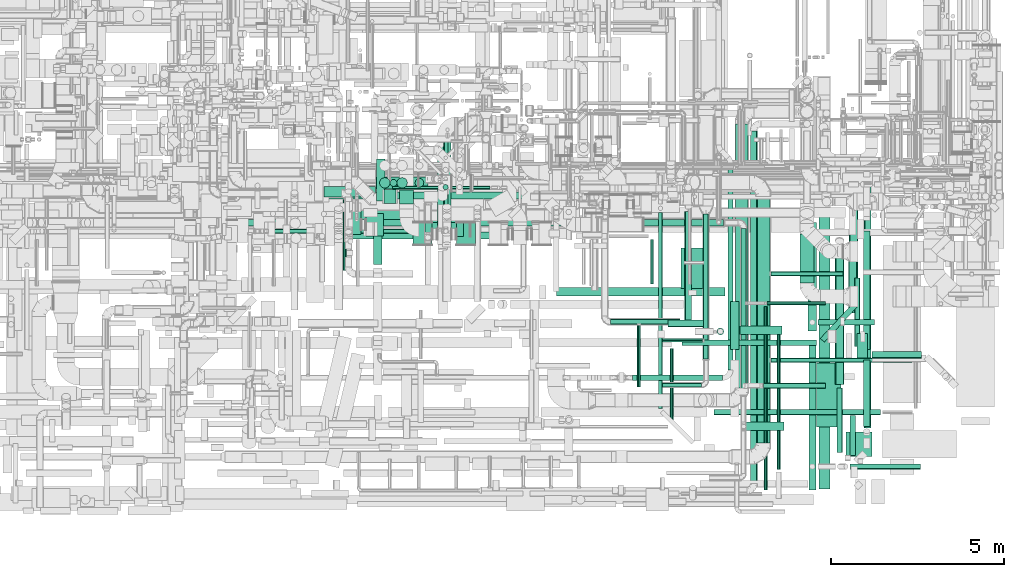
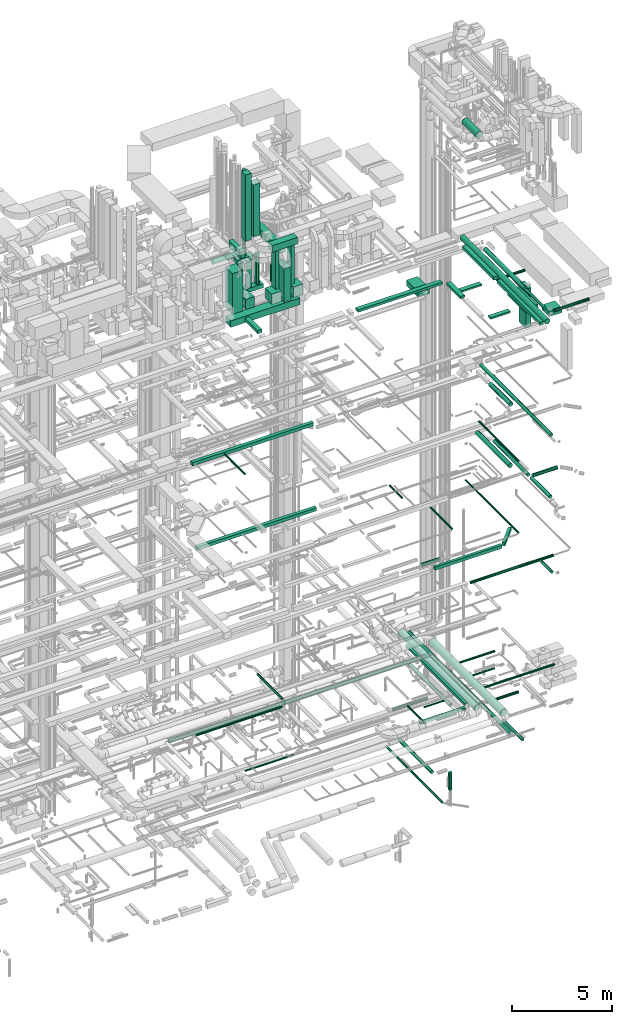
# One storey, part 50 of 337: 79 flow segments.
"""IFC2X3 building model written with IfcOpenShell, lengths in millimetres."""

from ifc_helpers import new_model, entity, si_unit, converted_unit, derived_unit, direction, frame, origin, origin_2d_with_axis, place, context, subcontext, project, spatial, rectangle, circle, extrude, type_object, element, save


model = new_model("IFC2X3")

# Units and contexts
model_context = context("Model", 3, precision=0.01, world=origin(), true_north=direction((6.12303176911189e-17, 1.0)))
body_context = subcontext(model_context, "Body", "Model", "MODEL_VIEW")
ifc_project = project(units=[si_unit("LENGTHUNIT", "METRE", prefix="MILLI"), si_unit("AREAUNIT", "SQUARE_METRE"), si_unit("VOLUMEUNIT", "CUBIC_METRE"), converted_unit("PLANEANGLEUNIT", "DEGREE", entity("IfcRatioMeasure", 0.0174532925199433), si_unit("PLANEANGLEUNIT", "RADIAN"), dimensions=[0, 0, 0, 0, 0, 0, 0]), si_unit("MASSUNIT", "GRAM", prefix="KILO"), derived_unit("MASSDENSITYUNIT", [(si_unit("MASSUNIT", "GRAM", prefix="KILO"), 1), (si_unit("LENGTHUNIT", "METRE"), -3)]), derived_unit("MOMENTOFINERTIAUNIT", [(si_unit("LENGTHUNIT", "METRE"), 4)]), si_unit("TIMEUNIT", "SECOND"), si_unit("FREQUENCYUNIT", "HERTZ"), si_unit("THERMODYNAMICTEMPERATUREUNIT", "DEGREE_CELSIUS"), derived_unit("THERMALTRANSMITTANCEUNIT", [(si_unit("MASSUNIT", "GRAM", prefix="KILO"), 1), (si_unit("THERMODYNAMICTEMPERATUREUNIT", "KELVIN"), -1), (si_unit("TIMEUNIT", "SECOND"), -3)]), derived_unit("VOLUMETRICFLOWRATEUNIT", [(si_unit("LENGTHUNIT", "METRE"), 3), (si_unit("TIMEUNIT", "SECOND"), -1)]), derived_unit("MASSFLOWRATEUNIT", [(si_unit("MASSUNIT", "GRAM", prefix="KILO"), 1), (si_unit("TIMEUNIT", "SECOND"), -1)]), derived_unit("ROTATIONALFREQUENCYUNIT", [(si_unit("TIMEUNIT", "SECOND"), -1)]), si_unit("ELECTRICCURRENTUNIT", "AMPERE"), si_unit("ELECTRICVOLTAGEUNIT", "VOLT"), si_unit("POWERUNIT", "WATT"), si_unit("FORCEUNIT", "NEWTON", prefix="KILO"), si_unit("ILLUMINANCEUNIT", "LUX"), si_unit("LUMINOUSFLUXUNIT", "LUMEN"), si_unit("LUMINOUSINTENSITYUNIT", "CANDELA"), derived_unit("USERDEFINED", [(si_unit("MASSUNIT", "GRAM", prefix="KILO"), -1), (si_unit("LENGTHUNIT", "METRE"), -2), (si_unit("TIMEUNIT", "SECOND"), 3), (si_unit("LUMINOUSFLUXUNIT", "LUMEN"), 1)]), derived_unit("LINEARVELOCITYUNIT", [(si_unit("LENGTHUNIT", "METRE"), 1), (si_unit("TIMEUNIT", "SECOND"), -1)]), si_unit("PRESSUREUNIT", "PASCAL"), derived_unit("USERDEFINED", [(si_unit("LENGTHUNIT", "METRE"), -2), (si_unit("MASSUNIT", "GRAM", prefix="KILO"), 1), (si_unit("TIMEUNIT", "SECOND"), -2)]), derived_unit("LINEARFORCEUNIT", [(si_unit("MASSUNIT", "GRAM", prefix="KILO"), 1), (si_unit("LENGTHUNIT", "METRE"), 1), (si_unit("TIMEUNIT", "SECOND"), -2), (si_unit("LENGTHUNIT", "METRE"), -1)]), derived_unit("PLANARFORCEUNIT", [(si_unit("MASSUNIT", "GRAM", prefix="KILO"), 1), (si_unit("LENGTHUNIT", "METRE"), 1), (si_unit("TIMEUNIT", "SECOND"), -2), (si_unit("LENGTHUNIT", "METRE"), -2)])], contexts=[model_context])

# Site, building, storey
site_placement = place(None, origin())
site = spatial("IfcSite", under=ifc_project, at=site_placement, CompositionType="ELEMENT")
building_placement = place(site_placement, origin())
building = spatial("IfcBuilding", under=site, at=building_placement, CompositionType="ELEMENT")
storey_placement = place(building_placement, origin())
storey = spatial("IfcBuildingStorey", under=building, at=storey_placement, CompositionType="ELEMENT", Elevation=0.0)

# Flow segments
duct_segment_type_1 = type_object("IfcDuctSegmentType", PredefinedType="NOTDEFINED")
flow_segment_1_placement = place(storey_placement, frame((63957.3, 5040.54, 11300.0)))
element("IfcFlowSegment", 1, at=flow_segment_1_placement, inside=storey, type_object=duct_segment_type_1, context=body_context, shape_type="SweptSolid", body=[
    extrude(rectangle(XDim=3879.99315375869, YDim=160.0, at=origin_2d_with_axis()), frame((1940.0, 80.0, 0.0)), (0.0, 0.0, 1.0), 200.000000000002),
])
flow_segment_2_placement = place(storey_placement, frame((67947.0, 5139.12, 11300.0)))
element("IfcFlowSegment", 2, at=flow_segment_2_placement, inside=storey, type_object=duct_segment_type_1, context=body_context, shape_type="SweptSolid", body=[
    extrude(rectangle(XDim=1391.87259618043, YDim=160.0, at=origin_2d_with_axis()), frame((533.14, 563.54, 0.0), z_axis=(0.0, 0.0, 1.0), x_axis=(0.681998360062502, 0.731353701619168, 0.0)), (0.0, 0.0, 1.0), 200.000000000002),
])
flow_segment_3_placement = place(storey_placement, frame((65279.05, 4335.29, 2975.0)))
element("IfcFlowSegment", 3, at=flow_segment_3_placement, inside=storey, type_object=duct_segment_type_1, context=body_context, shape_type="SweptSolid", body=[
    extrude(rectangle(XDim=5969.10852762841, YDim=150.000000000001, at=origin_2d_with_axis()), frame((75.0, 2984.55, 0.0), z_axis=(0.0, 0.0, 1.0), x_axis=(0.0, 1.0, 0.0)), (0.0, 0.0, 1.0), 149.999999999999),
])
flow_segment_4_placement = place(storey_placement, frame((52369.84, 9270.12, 19175.0)))
element("IfcFlowSegment", 4, at=flow_segment_4_placement, inside=storey, type_object=duct_segment_type_1, context=body_context, shape_type="SweptSolid", body=[
    extrude(rectangle(XDim=7010.00000000003, YDim=200.0, at=origin_2d_with_axis()), frame((3505.0, 100.0, 0.0)), (0.0, 0.0, 1.0), 200.000000000002),
])
flow_segment_5_placement = place(storey_placement, frame((51960.56, 8119.63, 14850.0)))
element("IfcFlowSegment", 5, at=flow_segment_5_placement, inside=storey, type_object=duct_segment_type_1, context=body_context, shape_type="SweptSolid", body=[
    extrude(rectangle(XDim=6930.00000000004, YDim=200.0, at=origin_2d_with_axis()), frame((3465.0, 100.0, 0.0)), (0.0, 0.0, 1.0), 199.999999999998),
])
flow_segment_6_placement = place(storey_placement, frame((54240.7, 8674.98, 27350.0)))
element("IfcFlowSegment", 6, at=flow_segment_6_placement, inside=storey, type_object=duct_segment_type_1, context=body_context, shape_type="SweptSolid", body=[
    extrude(rectangle(XDim=4013.85955351197, YDim=500.0, at=origin_2d_with_axis()), frame((2006.93, 250.0, 0.0)), (0.0, 0.0, 1.0), 400.000000000004),
])
flow_segment_7_placement = place(storey_placement, frame((67591.73, 5468.12, 27500.0)))
element("IfcFlowSegment", 7, at=flow_segment_7_placement, inside=storey, type_object=duct_segment_type_1, context=body_context, shape_type="SweptSolid", body=[
    extrude(rectangle(XDim=3131.89999999988, YDim=250.000000000004, at=origin_2d_with_axis()), frame((125.0, 1565.95, 0.0), z_axis=(0.0, 0.0, 1.0), x_axis=(0.0, -1.0, 0.0)), (0.0, 0.0, 1.0), 199.999999999998),
])
flow_segment_8_placement = place(storey_placement, frame((67616.73, 868.12, 27500.0)))
element("IfcFlowSegment", 8, at=flow_segment_8_placement, inside=storey, type_object=duct_segment_type_1, context=body_context, shape_type="SweptSolid", body=[
    extrude(rectangle(XDim=4300.00000000001, YDim=199.999999999998, at=origin_2d_with_axis()), frame((100.0, 2150.0, 0.0), z_axis=(0.0, 0.0, 1.0), x_axis=(0.0, -1.0, 0.0)), (0.0, 0.0, 1.0), 199.999999999998),
])
flow_segment_9_placement = place(storey_placement, frame((55054.59, 7386.33, 27450.0)))
element("IfcFlowSegment", 9, at=flow_segment_9_placement, inside=storey, type_object=duct_segment_type_1, context=body_context, shape_type="SweptSolid", body=[
    extrude(rectangle(XDim=1268.64626439159, YDim=250.000000000004, at=origin_2d_with_axis()), frame((125.0, 634.32, 0.0), z_axis=(0.0, 0.0, 1.0), x_axis=(0.0, -1.0, 0.0)), (0.0, 0.0, 1.0), 199.999999999998),
])
flow_segment_10_placement = place(storey_placement, frame((60329.77, 6466.66, 27475.0)))
element("IfcFlowSegment", 10, at=flow_segment_10_placement, inside=storey, type_object=duct_segment_type_1, context=body_context, shape_type="SweptSolid", body=[
    extrude(rectangle(XDim=4874.80009200001, YDim=250.000000000001, at=origin_2d_with_axis()), frame((2437.4, 125.0, 0.0), z_axis=(0.0, 0.0, 1.0), x_axis=(-1.0, 0.0, 0.0)), (0.0, 0.0, 1.0), 150.000000000001),
])
flow_segment_11_placement = place(storey_placement, frame((65354.57, 4924.16, 27475.0)))
element("IfcFlowSegment", 11, at=flow_segment_11_placement, inside=storey, type_object=duct_segment_type_1, context=body_context, shape_type="SweptSolid", body=[
    extrude(rectangle(XDim=1392.50000000006, YDim=250.000000000004, at=origin_2d_with_axis()), frame((125.0, 696.25, 0.0), z_axis=(0.0, 0.0, 1.0), x_axis=(0.0, -1.0, 0.0)), (0.0, 0.0, 1.0), 150.000000000001),
])
flow_segment_12_placement = place(storey_placement, frame((65754.57, 2587.91, 27500.0)))
element("IfcFlowSegment", 12, at=flow_segment_12_placement, inside=storey, type_object=duct_segment_type_1, context=body_context, shape_type="SweptSolid", body=[
    extrude(rectangle(XDim=1145.00000000007, YDim=250.0, at=origin_2d_with_axis()), frame((572.5, 125.0, 0.0)), (0.0, 0.0, 1.0), 100.000000000003),
])
flow_segment_13_placement = place(storey_placement, frame((65624.57, 5356.95, 27500.0)))
element("IfcFlowSegment", 13, at=flow_segment_13_placement, inside=storey, type_object=duct_segment_type_1, context=body_context, shape_type="SweptSolid", body=[
    extrude(rectangle(XDim=1220.0, YDim=249.999999999999, at=origin_2d_with_axis()), frame((610.0, 125.0, 0.0)), (0.0, 0.0, 1.0), 100.000000000003),
])
flow_segment_14_placement = place(storey_placement, frame((68692.59, 1843.42, 27085.0)))
element("IfcFlowSegment", 14, at=flow_segment_14_placement, inside=storey, type_object=duct_segment_type_1, context=body_context, shape_type="SweptSolid", body=[
    extrude(rectangle(XDim=751.874999999965, YDim=700.0, at=origin_2d_with_axis()), frame((375.94, 350.0, 0.0)), (0.0, 0.0, 1.0), 300.000000000001),
])
flow_segment_15_placement = place(storey_placement, frame((67842.59, 2693.42, 27085.0)))
element("IfcFlowSegment", 15, at=flow_segment_15_placement, inside=storey, type_object=duct_segment_type_1, context=body_context, shape_type="SweptSolid", body=[
    extrude(rectangle(XDim=1839.99999999995, YDim=699.999999999997, at=origin_2d_with_axis()), frame((350.0, 920.0, 0.0), z_axis=(0.0, 0.0, 1.0), x_axis=(0.0, 1.0, 0.0)), (0.0, 0.0, 1.0), 300.000000000001),
])
flow_segment_16_placement = place(storey_placement, frame((69006.97, 4683.42, 24535.0)))
element("IfcFlowSegment", 16, at=flow_segment_16_placement, inside=storey, type_object=duct_segment_type_1, context=body_context, shape_type="SweptSolid", body=[
    extrude(rectangle(XDim=700.0, YDim=300.000000000001, at=origin_2d_with_axis()), frame((150.0, 350.0, 0.0), z_axis=(0.0, 0.0, 1.0), x_axis=(0.0, 1.0, 0.0)), (0.0, 0.0, 1.0), 2400.00000000001),
])
flow_segment_17_placement = place(storey_placement, frame((54088.0, 8245.5, 28462.0)))
element("IfcFlowSegment", 17, at=flow_segment_17_placement, inside=storey, type_object=duct_segment_type_1, context=body_context, shape_type="SweptSolid", body=[
    extrude(rectangle(XDim=600.000000000002, YDim=700.0, at=origin_2d_with_axis()), frame((300.0, 350.0, 0.0), z_axis=(0.0, 0.0, 1.0), x_axis=(-1.0, 0.0, 0.0)), (0.0, 0.0, 1.0), 2487.99999999994),
])
flow_segment_18_placement = place(storey_placement, frame((56897.0, 8504.29, 31000.0)))
element("IfcFlowSegment", 18, at=flow_segment_18_placement, inside=storey, type_object=duct_segment_type_1, context=body_context, shape_type="SweptSolid", body=[
    extrude(rectangle(XDim=2585.02945260871, YDim=400.000000000004, at=origin_2d_with_axis()), frame((200.0, 1292.51, 0.0), z_axis=(0.0, 0.0, 1.0), x_axis=(0.0, -1.0, 0.0)), (0.0, 0.0, 1.0), 399.999999999996),
])
flow_segment_19_placement = place(storey_placement, frame((56897.0, 7954.21, 28417.57)))
element("IfcFlowSegment", 19, at=flow_segment_19_placement, inside=storey, type_object=duct_segment_type_1, context=body_context, shape_type="SweptSolid", body=[
    extrude(rectangle(XDim=800.000000000001, YDim=400.000000000004, at=origin_2d_with_axis()), frame((200.0, 400.0, 0.0), z_axis=(0.0, 0.0, 1.0), x_axis=(0.0, -1.0, 0.0)), (0.0, 0.0, 1.0), 2014.6001016),
])
for number, where in (
    (20, (56197.0, 7958.29, 28502.0)),
    (21, (57447.0, 7958.29, 28502.0)),
):
    element("IfcFlowSegment", number, at=place(storey_placement, frame(where)), inside=storey, type_object=duct_segment_type_1, context=body_context, shape_type="SweptSolid", body=[
        extrude(rectangle(XDim=630.0, YDim=549.999999999996, at=origin_2d_with_axis()), frame((275.0, 315.0, 0.0), z_axis=(0.0, 0.0, 1.0), x_axis=(0.0, 1.0, 0.0)), (0.0, 0.0, 1.0), 630.000000000004),
    ])
for number, where in (
    (22, (56547.0, 8188.29, 29152.0)),
    (23, (57447.0, 8188.29, 29152.0)),
):
    element("IfcFlowSegment", number, at=place(storey_placement, frame(where)), inside=storey, type_object=duct_segment_type_1, context=body_context, shape_type="SweptSolid", body=[
        extrude(rectangle(XDim=400.0, YDim=199.999999999998, at=origin_2d_with_axis()), frame((100.0, 200.0, 0.0), z_axis=(0.0, 0.0, 1.0), x_axis=(0.0, 1.0, 0.0)), (0.0, 0.0, 1.0), 2328.0),
    ])
flow_segment_20_placement = place(storey_placement, frame((56361.0, 8188.29, 31500.0)))
element("IfcFlowSegment", 24, at=flow_segment_20_placement, inside=storey, type_object=duct_segment_type_1, context=body_context, shape_type="SweptSolid", body=[
    extrude(rectangle(XDim=1467.5, YDim=400.0, at=origin_2d_with_axis()), frame((733.75, 200.0, 0.0), z_axis=(0.0, 0.0, 1.0), x_axis=(-1.0, 0.0, 0.0)), (0.0, 0.0, 1.0), 399.999999999996),
])
flow_segment_21_placement = place(storey_placement, frame((55811.0, 9133.0, 32050.0)))
element("IfcFlowSegment", 25, at=flow_segment_21_placement, inside=storey, type_object=duct_segment_type_1, context=body_context, shape_type="SweptSolid", body=[
    extrude(rectangle(XDim=400.0, YDim=400.000000000004, at=origin_2d_with_axis()), frame((200.0, 200.0, 0.0), z_axis=(0.0, 0.0, 1.0), x_axis=(0.0, -1.0, 0.0)), (0.0, 0.0, 1.0), 3175.169278549),
])
flow_segment_22_placement = place(storey_placement, frame((55137.5, 9218.1, 30900.0)))
element("IfcFlowSegment", 26, at=flow_segment_22_placement, inside=storey, type_object=duct_segment_type_1, context=body_context, shape_type="SweptSolid", body=[
    extrude(rectangle(XDim=1208.13888831955, YDim=250.000000000004, at=origin_2d_with_axis()), frame((125.0, 604.07, 0.0), z_axis=(0.0, 0.0, 1.0), x_axis=(0.0, 1.0, 0.0)), (0.0, 0.0, 1.0), 399.999999999996),
])
flow_segment_23_placement = place(storey_placement, frame((54838.0, 8207.5, 28512.0)))
element("IfcFlowSegment", 27, at=flow_segment_23_placement, inside=storey, type_object=duct_segment_type_1, context=body_context, shape_type="SweptSolid", body=[
    extrude(rectangle(XDim=639.502411801508, YDim=499.999999999999, at=origin_2d_with_axis()), frame((250.0, 319.75, 0.0), z_axis=(0.0, 0.0, 1.0), x_axis=(0.0, -1.0, 0.0)), (0.0, 0.0, 1.0), 619.999999999998),
])
flow_segment_24_placement = place(storey_placement, frame((55357.08, 9148.0, 31920.0)))
element("IfcFlowSegment", 28, at=flow_segment_24_placement, inside=storey, type_object=duct_segment_type_1, context=body_context, shape_type="SweptSolid", body=[
    extrude(rectangle(XDim=350.000000000007, YDim=400.0, at=origin_2d_with_axis()), frame((175.0, 200.0, 0.0)), (0.0, 0.0, 1.0), 4059.99998675864),
])
flow_segment_25_placement = place(storey_placement, frame((55133.85, 9561.5, 28400.0)))
element("IfcFlowSegment", 29, at=flow_segment_25_placement, inside=storey, type_object=duct_segment_type_1, context=body_context, shape_type="SweptSolid", body=[
    extrude(rectangle(XDim=1500.0, YDim=349.999999999999, at=origin_2d_with_axis()), frame((750.0, 175.0, 0.0), z_axis=(0.0, 0.0, 1.0), x_axis=(-1.0, 0.0, 0.0)), (0.0, 0.0, 1.0), 250.000000000004),
])
flow_segment_26_placement = place(storey_placement, frame((55128.85, 9561.5, 30350.0)))
element("IfcFlowSegment", 30, at=flow_segment_26_placement, inside=storey, type_object=duct_segment_type_1, context=body_context, shape_type="SweptSolid", body=[
    extrude(rectangle(XDim=999.999999999998, YDim=349.999999999999, at=origin_2d_with_axis()), frame((500.0, 175.0, 0.0), z_axis=(0.0, 0.0, 1.0), x_axis=(-1.0, 0.0, 0.0)), (0.0, 0.0, 1.0), 250.000000000004),
])
flow_segment_27_placement = place(storey_placement, frame((63931.44, 6695.18, 27000.0)))
element("IfcFlowSegment", 31, at=flow_segment_27_placement, inside=storey, type_object=duct_segment_type_1, context=body_context, shape_type="SweptSolid", body=[
    extrude(rectangle(XDim=1168.29999999998, YDim=650.0, at=origin_2d_with_axis()), frame((325.0, 584.15, 0.0), z_axis=(0.0, 0.0, 1.0), x_axis=(0.0, 1.0, 0.0)), (0.0, 0.0, 1.0), 349.999999999998),
])
flow_segment_28_placement = place(storey_placement, frame((62535.0, 4035.29, 2975.0)))
element("IfcFlowSegment", 32, at=flow_segment_28_placement, inside=storey, type_object=duct_segment_type_1, context=body_context, shape_type="SweptSolid", body=[
    extrude(rectangle(XDim=2594.04811743086, YDim=150.0, at=origin_2d_with_axis()), frame((1297.02, 75.0, 0.0), z_axis=(0.0, 0.0, 1.0), x_axis=(-1.0, 0.0, 0.0)), (0.0, 0.0, 1.0), 149.999999999999),
])
duct_segment_type_2 = type_object("IfcDuctSegmentType", PredefinedType="NOTDEFINED")
flow_segment_29_placement = place(storey_placement, frame((68932.9, 5014.74, -881.6)))
element("IfcFlowSegment", 33, at=flow_segment_29_placement, inside=storey, type_object=duct_segment_type_2, context=body_context, shape_type="SweptSolid", body=[
    extrude(circle(Radius=80.0, at=origin_2d_with_axis()), frame((81.6, 0.0, 81.6), z_axis=(0.0, 1.0, 0.0), x_axis=(-1.0, 0.0, 0.0)), (0.0, 0.0, 1.0), 1980.00000000001),
])
flow_segment_30_placement = place(storey_placement, frame((63274.01, 3226.48, -1614.1)))
element("IfcFlowSegment", 34, at=flow_segment_30_placement, inside=storey, type_object=duct_segment_type_2, context=body_context, shape_type="SweptSolid", body=[
    extrude(circle(Radius=62.5, at=origin_2d_with_axis()), frame((64.1, 0.0, 64.1), z_axis=(0.0, 1.0, 0.0), x_axis=(1.0, 0.0, 0.0)), (0.0, 0.0, 1.0), 5649.58886470343),
])
flow_segment_31_placement = place(storey_placement, frame((55604.18, 9547.39, -836.6)))
element("IfcFlowSegment", 35, at=flow_segment_31_placement, inside=storey, type_object=duct_segment_type_2, context=body_context, shape_type="SweptSolid", body=[
    extrude(circle(Radius=50.0, at=origin_2d_with_axis()), frame((0.0, 51.6, 51.6), z_axis=(1.0, 0.0, 0.0), x_axis=(0.0, 1.0, 0.0)), (0.0, 0.0, 1.0), 2811.83896376268),
])
flow_segment_32_placement = place(storey_placement, frame((64032.19, 5648.45, -1551.6)))
element("IfcFlowSegment", 36, at=flow_segment_32_placement, inside=storey, type_object=duct_segment_type_2, context=body_context, shape_type="SweptSolid", body=[
    extrude(circle(Radius=100.0, at=origin_2d_with_axis()), frame((101.6, 0.0, 101.6), z_axis=(0.0, 1.0, 0.0), x_axis=(1.0, 0.0, 0.0)), (0.0, 0.0, 1.0), 3257.69167752536),
])
flow_segment_33_placement = place(storey_placement, frame((64961.87, 5346.85, -2711.99)))
element("IfcFlowSegment", 37, at=flow_segment_33_placement, inside=storey, type_object=duct_segment_type_2, context=body_context, shape_type="SweptSolid", body=[
    extrude(circle(Radius=100.0, at=origin_2d_with_axis()), frame((101.6, 101.6, 0.0), z_axis=(0.0, 0.0, 1.0), x_axis=(0.0, 1.0, 0.0)), (0.0, 0.0, 1.0), 1061.986871),
])
flow_segment_34_placement = place(storey_placement, frame((65504.14, 3819.15, 2870.9)))
element("IfcFlowSegment", 38, at=flow_segment_34_placement, inside=storey, type_object=duct_segment_type_2, context=body_context, shape_type="SweptSolid", body=[
    extrude(circle(Radius=177.5, at=origin_2d_with_axis()), frame((179.1, 0.0, 179.1), z_axis=(0.0, 1.0, 0.0), x_axis=(1.0, 0.0, 0.0)), (0.0, 0.0, 1.0), 7615.00000000007),
])
flow_segment_35_placement = place(storey_placement, frame((64566.67, 4649.91, 2968.4)))
element("IfcFlowSegment", 39, at=flow_segment_35_placement, inside=storey, type_object=duct_segment_type_2, context=body_context, shape_type="SweptSolid", body=[
    extrude(circle(Radius=80.0, at=origin_2d_with_axis()), frame((81.6, 0.0, 81.6), z_axis=(0.0, 1.0, 0.0), x_axis=(1.0, 0.0, 0.0)), (0.0, 0.0, 1.0), 4184.99999999999),
])
flow_segment_36_placement = place(storey_placement, frame((63393.27, 3840.82, 2985.9)))
element("IfcFlowSegment", 40, at=flow_segment_36_placement, inside=storey, type_object=duct_segment_type_2, context=body_context, shape_type="SweptSolid", body=[
    extrude(circle(Radius=62.5, at=origin_2d_with_axis()), frame((0.0, 64.1, 64.1), z_axis=(1.0, 0.0, 0.0), x_axis=(0.0, 1.0, 0.0)), (0.0, 0.0, 1.0), 1130.0),
])
flow_segment_37_placement = place(storey_placement, frame((50581.4, 8485.07, 3298.4)))
element("IfcFlowSegment", 41, at=flow_segment_37_placement, inside=storey, type_object=duct_segment_type_2, context=body_context, shape_type="SweptSolid", body=[
    extrude(circle(Radius=100.0, at=origin_2d_with_axis()), frame((0.0, 101.6, 101.6), z_axis=(1.0, 0.0, 0.0), x_axis=(0.0, -1.0, 0.0)), (0.0, 0.0, 1.0), 14575.0),
])
flow_segment_38_placement = place(storey_placement, frame((63553.0, 5578.95, 11298.4)))
element("IfcFlowSegment", 42, at=flow_segment_38_placement, inside=storey, type_object=duct_segment_type_2, context=body_context, shape_type="SweptSolid", body=[
    extrude(circle(Radius=100.0, at=origin_2d_with_axis()), frame((0.0, 101.6, 101.6), z_axis=(1.0, 0.0, 0.0), x_axis=(0.0, -1.0, 0.0)), (0.0, 0.0, 1.0), 1019.99999999997),
])
flow_segment_39_placement = place(storey_placement, frame((64881.92, 3041.28, 11318.4)))
element("IfcFlowSegment", 43, at=flow_segment_39_placement, inside=storey, type_object=duct_segment_type_2, context=body_context, shape_type="SweptSolid", body=[
    extrude(circle(Radius=80.0, at=origin_2d_with_axis()), frame((0.0, 81.6, 81.6), z_axis=(1.0, 0.0, 0.0), x_axis=(0.0, -1.0, 0.0)), (0.0, 0.0, 1.0), 4800.0),
])
flow_segment_40_placement = place(storey_placement, frame((69437.53, 4672.98, 15248.19)))
element("IfcFlowSegment", 44, at=flow_segment_40_placement, inside=storey, type_object=duct_segment_type_2, context=body_context, shape_type="SweptSolid", body=[
    extrude(circle(Radius=100.0, at=origin_2d_with_axis()), frame((0.0, 101.6, 101.6), z_axis=(1.0, 0.0, 0.0), x_axis=(0.0, -1.0, 0.0)), (0.0, 0.0, 1.0), 1426.66539867532),
])
flow_segment_41_placement = place(storey_placement, frame((69185.94, 2713.21, 15248.4)))
element("IfcFlowSegment", 45, at=flow_segment_41_placement, inside=storey, type_object=duct_segment_type_2, context=body_context, shape_type="SweptSolid", body=[
    extrude(circle(Radius=100.0, at=origin_2d_with_axis()), frame((101.6, 0.0, 101.6), z_axis=(0.0, 1.0, 0.0), x_axis=(-1.0, 0.0, 0.0)), (0.0, 0.0, 1.0), 1911.36381752538),
])
flow_segment_42_placement = place(storey_placement, frame((68800.4, 1862.88, 11318.4)))
element("IfcFlowSegment", 46, at=flow_segment_42_placement, inside=storey, type_object=duct_segment_type_2, context=body_context, shape_type="SweptSolid", body=[
    extrude(circle(Radius=80.0, at=origin_2d_with_axis()), frame((81.6, 0.0, 81.6), z_axis=(0.0, 1.0, 0.0), x_axis=(-1.0, 0.0, 0.0)), (0.0, 0.0, 1.0), 1159.99999999996),
])
flow_segment_43_placement = place(storey_placement, frame((68780.34, 6072.09, 15223.4)))
element("IfcFlowSegment", 47, at=flow_segment_43_placement, inside=storey, type_object=duct_segment_type_2, context=body_context, shape_type="SweptSolid", body=[
    extrude(circle(Radius=125.0, at=origin_2d_with_axis()), frame((126.6, 0.0, 126.6), z_axis=(0.0, 1.0, 0.0), x_axis=(-1.0, 0.0, 0.0)), (0.0, 0.0, 1.0), 3327.25248000003),
])
flow_segment_44_placement = place(storey_placement, frame((52018.34, 8278.42, 3335.9)))
element("IfcFlowSegment", 48, at=flow_segment_44_placement, inside=storey, type_object=duct_segment_type_2, context=body_context, shape_type="SweptSolid", body=[
    extrude(circle(Radius=62.5, at=origin_2d_with_axis()), frame((0.0, 64.1, 64.1), z_axis=(1.0, 0.0, 0.0), x_axis=(0.0, 1.0, 0.0)), (0.0, 0.0, 1.0), 4999.06282419044),
])
flow_segment_45_placement = place(storey_placement, frame((57078.31, 8467.51, 3670.9)))
element("IfcFlowSegment", 49, at=flow_segment_45_placement, inside=storey, type_object=duct_segment_type_2, context=body_context, shape_type="SweptSolid", body=[
    extrude(circle(Radius=62.5, at=origin_2d_with_axis()), frame((64.1, 0.0, 64.1), z_axis=(0.0, 1.0, 0.0), x_axis=(1.0, 0.0, 0.0)), (0.0, 0.0, 1.0), 2536.60000000001),
])
flow_segment_46_placement = place(storey_placement, frame((65927.76, 1062.18, 2948.4)))
element("IfcFlowSegment", 50, at=flow_segment_46_placement, inside=storey, type_object=duct_segment_type_2, context=body_context, shape_type="SweptSolid", body=[
    extrude(circle(Radius=100.0, at=origin_2d_with_axis()), frame((101.6, 0.0, 101.6), z_axis=(0.0, 1.0, 0.0), x_axis=(-1.0, 0.0, 0.0)), (0.0, 0.0, 1.0), 10177.1607973862),
])
flow_segment_47_placement = place(storey_placement, frame((66692.51, 1458.31, 19123.4)))
element("IfcFlowSegment", 51, at=flow_segment_47_placement, inside=storey, type_object=duct_segment_type_2, context=body_context, shape_type="SweptSolid", body=[
    extrude(circle(Radius=50.0, at=origin_2d_with_axis()), frame((51.6, 0.0, 51.6), z_axis=(0.0, 1.0, 0.0), x_axis=(1.0, 0.0, 0.0)), (0.0, 0.0, 1.0), 4034.99999999999),
])
flow_segment_48_placement = place(storey_placement, frame((68762.84, 5986.78, 19023.4)))
element("IfcFlowSegment", 52, at=flow_segment_48_placement, inside=storey, type_object=duct_segment_type_2, context=body_context, shape_type="SweptSolid", body=[
    extrude(circle(Radius=125.0, at=origin_2d_with_axis()), frame((126.6, 0.0, 126.6), z_axis=(0.0, 1.0, 0.0), x_axis=(1.0, 0.0, 0.0)), (0.0, 0.0, 1.0), 2050.00000000001),
])
flow_segment_49_placement = place(storey_placement, frame((54167.95, 7211.98, 19223.4)))
element("IfcFlowSegment", 53, at=flow_segment_49_placement, inside=storey, type_object=duct_segment_type_2, context=body_context, shape_type="SweptSolid", body=[
    extrude(circle(Radius=50.0, at=origin_2d_with_axis()), frame((51.6, 0.0, 51.6), z_axis=(0.0, 1.0, 0.0), x_axis=(-1.0, 0.0, 0.0)), (0.0, 0.0, 1.0), 2038.14341585322),
])
flow_segment_50_placement = place(storey_placement, frame((63604.41, 2800.44, 15248.4)))
element("IfcFlowSegment", 54, at=flow_segment_50_placement, inside=storey, type_object=duct_segment_type_2, context=body_context, shape_type="SweptSolid", body=[
    extrude(circle(Radius=50.0, at=origin_2d_with_axis()), frame((51.6, 0.0, 51.6), z_axis=(0.0, 1.0, 0.0), x_axis=(1.0, 0.0, 0.0)), (0.0, 0.0, 1.0), 2162.50000000007),
])
flow_segment_51_placement = place(storey_placement, frame((63038.96, 6819.63, 14898.4)))
element("IfcFlowSegment", 55, at=flow_segment_51_placement, inside=storey, type_object=duct_segment_type_2, context=body_context, shape_type="SweptSolid", body=[
    extrude(circle(Radius=50.0, at=origin_2d_with_axis()), frame((51.6, 0.0, 51.6), z_axis=(0.0, 1.0, 0.0), x_axis=(-1.0, 0.0, 0.0)), (0.0, 0.0, 1.0), 1280.00000000003),
])
flow_segment_52_placement = place(storey_placement, frame((66316.85, 870.66, 15248.4)))
element("IfcFlowSegment", 56, at=flow_segment_52_placement, inside=storey, type_object=duct_segment_type_2, context=body_context, shape_type="SweptSolid", body=[
    extrude(circle(Radius=50.0, at=origin_2d_with_axis()), frame((51.6, 0.0, 51.6), z_axis=(0.0, 1.0, 0.0), x_axis=(1.0, 0.0, 0.0)), (0.0, 0.0, 1.0), 5300.00000000001),
])
flow_segment_53_placement = place(storey_placement, frame((69185.94, 4924.58, 15248.4)))
element("IfcFlowSegment", 57, at=flow_segment_53_placement, inside=storey, type_object=duct_segment_type_2, context=body_context, shape_type="SweptSolid", body=[
    extrude(circle(Radius=100.0, at=origin_2d_with_axis()), frame((101.6, 0.0, 101.6), z_axis=(0.0, 1.0, 0.0), x_axis=(1.0, 0.0, 0.0)), (0.0, 0.0, 1.0), 3422.52195486601),
])
flow_segment_54_placement = place(storey_placement, frame((69212.2, 2664.07, 19048.4)))
element("IfcFlowSegment", 58, at=flow_segment_54_placement, inside=storey, type_object=duct_segment_type_2, context=body_context, shape_type="SweptSolid", body=[
    extrude(circle(Radius=100.0, at=origin_2d_with_axis()), frame((101.6, 0.0, 101.6), z_axis=(0.0, 1.0, 0.0), x_axis=(-1.0, 0.0, 0.0)), (0.0, 0.0, 1.0), 7039.99999999996),
])
flow_segment_55_placement = place(storey_placement, frame((68803.0, 1469.8, 27518.4)))
element("IfcFlowSegment", 59, at=flow_segment_55_placement, inside=storey, type_object=duct_segment_type_2, context=body_context, shape_type="SweptSolid", body=[
    extrude(circle(Radius=80.0, at=origin_2d_with_axis()), frame((0.0, 81.6, 81.6), z_axis=(1.0, 0.0, 0.0), x_axis=(0.0, -1.0, 0.0)), (0.0, 0.0, 1.0), 2033.72583002031),
])
flow_segment_56_placement = place(storey_placement, frame((67876.73, 5629.78, 27218.4)))
element("IfcFlowSegment", 60, at=flow_segment_56_placement, inside=storey, type_object=duct_segment_type_2, context=body_context, shape_type="SweptSolid", body=[
    extrude(circle(Radius=80.0, at=origin_2d_with_axis()), frame((0.0, 81.6, 81.6), z_axis=(1.0, 0.0, 0.0), x_axis=(0.0, -1.0, 0.0)), (0.0, 0.0, 1.0), 1640.00000000001),
])
flow_segment_57_placement = place(storey_placement, frame((68421.42, 1957.41, 27543.4)))
element("IfcFlowSegment", 61, at=flow_segment_57_placement, inside=storey, type_object=duct_segment_type_2, context=body_context, shape_type="SweptSolid", body=[
    extrude(circle(Radius=80.0, at=origin_2d_with_axis()), frame((81.6, 0.0, 81.6), z_axis=(0.0, 1.0, 0.0), x_axis=(-1.0, 0.0, 0.0)), (0.0, 0.0, 1.0), 1865.0),
])
flow_segment_58_placement = place(storey_placement, frame((67903.65, 908.17, 27430.9)))
element("IfcFlowSegment", 62, at=flow_segment_58_placement, inside=storey, type_object=duct_segment_type_2, context=body_context, shape_type="SweptSolid", body=[
    extrude(circle(Radius=157.5, at=origin_2d_with_axis()), frame((159.1, 0.0, 159.1), z_axis=(0.0, 1.0, 0.0), x_axis=(-1.0, 0.0, 0.0)), (0.0, 0.0, 1.0), 8485.81080780304),
])
flow_segment_59_placement = place(storey_placement, frame((67357.46, 6853.72, 35348.4)))
element("IfcFlowSegment", 63, at=flow_segment_59_placement, inside=storey, type_object=duct_segment_type_2, context=body_context, shape_type="SweptSolid", body=[
    extrude(circle(Radius=200.0, at=origin_2d_with_axis()), frame((201.6, 0.0, 201.6), z_axis=(0.0, 1.0, 0.0), x_axis=(1.0, 0.0, 0.0)), (0.0, 0.0, 1.0), 1402.73383723486),
])
flow_segment_60_placement = place(storey_placement, frame((53620.03, 9324.0, 30948.4)))
element("IfcFlowSegment", 64, at=flow_segment_60_placement, inside=storey, type_object=duct_segment_type_2, context=body_context, shape_type="SweptSolid", body=[
    extrude(circle(Radius=150.0, at=origin_2d_with_axis()), frame((0.0, 151.6, 151.6), z_axis=(1.0, 0.0, 0.0), x_axis=(0.0, 1.0, 0.0)), (0.0, 0.0, 1.0), 1497.46669999997),
])
flow_segment_61_placement = place(storey_placement, frame((57059.9, 9536.46, 28620.0)))
element("IfcFlowSegment", 65, at=flow_segment_61_placement, inside=storey, type_object=duct_segment_type_2, context=body_context, shape_type="SweptSolid", body=[
    extrude(circle(Radius=75.0, at=origin_2d_with_axis()), frame((76.6, 76.6, 0.0), z_axis=(0.0, 0.0, 1.0), x_axis=(-1.0, 0.0, 0.0)), (0.0, 0.0, 1.0), 1059.99999999997),
])
for number, where in (
    (66, (55228.4, 9584.9, 28670.0)),
    (67, (55728.4, 9584.9, 28670.0)),
):
    element("IfcFlowSegment", number, at=place(storey_placement, frame(where)), inside=storey, type_object=duct_segment_type_2, context=body_context, shape_type="SweptSolid", body=[
        extrude(circle(Radius=150.0, at=origin_2d_with_axis()), frame((151.6, 151.6, 0.0), z_axis=(0.0, 0.0, 1.0), x_axis=(0.0, 1.0, 0.0)), (0.0, 0.0, 1.0), 1659.99999999996),
    ])
flow_segment_62_placement = place(storey_placement, frame((56253.4, 9611.52, 28670.0)))
element("IfcFlowSegment", 68, at=flow_segment_62_placement, inside=storey, type_object=duct_segment_type_2, context=body_context, shape_type="SweptSolid", body=[
    extrude(circle(Radius=125.0, at=origin_2d_with_axis()), frame((126.6, 126.6, 0.0), z_axis=(0.0, 0.0, 1.0), x_axis=(0.0, -1.0, 0.0)), (0.0, 0.0, 1.0), 1877.2011515013),
])
flow_segment_63_placement = place(storey_placement, frame((55529.55, 9632.47, 30620.0)))
element("IfcFlowSegment", 69, at=flow_segment_63_placement, inside=storey, type_object=duct_segment_type_2, context=body_context, shape_type="SweptSolid", body=[
    extrude(circle(Radius=100.0, at=origin_2d_with_axis()), frame((101.6, 101.6, 0.0), z_axis=(0.0, 0.0, 1.0), x_axis=(0.0, 1.0, 0.0)), (0.0, 0.0, 1.0), 5257.46038474586),
])
flow_segment_64_placement = place(storey_placement, frame((68376.42, 3912.41, 27498.4)))
element("IfcFlowSegment", 70, at=flow_segment_64_placement, inside=storey, type_object=duct_segment_type_2, context=body_context, shape_type="SweptSolid", body=[
    extrude(circle(Radius=125.0, at=origin_2d_with_axis()), frame((126.6, 0.0, 126.6), z_axis=(0.0, 1.0, 0.0), x_axis=(1.0, 0.0, 0.0)), (0.0, 0.0, 1.0), 3963.22684140666),
])
flow_segment_65_placement = place(storey_placement, frame((61887.4, 5649.57, 3018.4)))
element("IfcFlowSegment", 71, at=flow_segment_65_placement, inside=storey, type_object=duct_segment_type_2, context=body_context, shape_type="SweptSolid", body=[
    extrude(circle(Radius=80.0, at=origin_2d_with_axis()), frame((0.0, 81.6, 81.6), z_axis=(1.0, 0.0, 0.0), x_axis=(0.0, -1.0, 0.0)), (0.0, 0.0, 1.0), 2010.00000000002),
])
flow_segment_66_placement = place(storey_placement, frame((62662.08, 3851.17, 3048.4)))
element("IfcFlowSegment", 72, at=flow_segment_66_placement, inside=storey, type_object=duct_segment_type_2, context=body_context, shape_type="SweptSolid", body=[
    extrude(circle(Radius=50.0, at=origin_2d_with_axis()), frame((51.6, 0.0, 51.6), z_axis=(0.0, 1.0, 0.0), x_axis=(-1.0, 0.0, 0.0)), (0.0, 0.0, 1.0), 1780.0),
])
flow_segment_67_placement = place(storey_placement, frame((66097.37, 2229.37, 3298.4)))
element("IfcFlowSegment", 73, at=flow_segment_67_placement, inside=storey, type_object=duct_segment_type_2, context=body_context, shape_type="SweptSolid", body=[
    extrude(circle(Radius=200.0, at=origin_2d_with_axis()), frame((201.6, 0.0, 201.6), z_axis=(0.0, 1.0, 0.0), x_axis=(-1.0, 0.0, 0.0)), (0.0, 0.0, 1.0), 7120.63326905055),
])
flow_segment_68_placement = place(storey_placement, frame((65653.08, 3610.46, 3318.4)))
element("IfcFlowSegment", 74, at=flow_segment_68_placement, inside=storey, type_object=duct_segment_type_2, context=body_context, shape_type="SweptSolid", body=[
    extrude(circle(Radius=80.0, at=origin_2d_with_axis()), frame((81.6, 0.0, 81.6), z_axis=(0.0, 1.0, 0.0), x_axis=(1.0, 0.0, 0.0)), (0.0, 0.0, 1.0), 4816.20887710619),
])
flow_segment_69_placement = place(storey_placement, frame((66518.97, 7048.97, 3435.9)))
element("IfcFlowSegment", 75, at=flow_segment_69_placement, inside=storey, type_object=duct_segment_type_2, context=body_context, shape_type="SweptSolid", body=[
    extrude(circle(Radius=62.5, at=origin_2d_with_axis()), frame((0.0, 64.1, 64.1), z_axis=(1.0, 0.0, 0.0), x_axis=(0.0, -1.0, 0.0)), (0.0, 0.0, 1.0), 2080.0),
])
flow_segment_70_placement = place(storey_placement, frame((66518.97, 4554.43, 3435.9)))
element("IfcFlowSegment", 76, at=flow_segment_70_placement, inside=storey, type_object=duct_segment_type_2, context=body_context, shape_type="SweptSolid", body=[
    extrude(circle(Radius=62.5, at=origin_2d_with_axis()), frame((0.0, 64.1, 64.1), z_axis=(1.0, 0.0, 0.0), x_axis=(0.0, -1.0, 0.0)), (0.0, 0.0, 1.0), 4079.99999999999),
])
flow_segment_71_placement = place(storey_placement, frame((63393.27, 5137.06, 2998.4)))
element("IfcFlowSegment", 77, at=flow_segment_71_placement, inside=storey, type_object=duct_segment_type_2, context=body_context, shape_type="SweptSolid", body=[
    extrude(circle(Radius=50.0, at=origin_2d_with_axis()), frame((0.0, 51.6, 51.6), z_axis=(1.0, 0.0, 0.0), x_axis=(0.0, 1.0, 0.0)), (0.0, 0.0, 1.0), 1155.00000000001),
])
flow_segment_72_placement = place(storey_placement, frame((66403.14, 6211.86, 3088.4)))
element("IfcFlowSegment", 78, at=flow_segment_72_placement, inside=storey, type_object=duct_segment_type_2, context=body_context, shape_type="SweptSolid", body=[
    extrude(circle(Radius=50.0, at=origin_2d_with_axis()), frame((0.0, 51.6, 51.6), z_axis=(1.0, 0.0, 0.0), x_axis=(0.0, -1.0, 0.0)), (0.0, 0.0, 1.0), 1700.56196908623),
])
flow_segment_73_placement = place(storey_placement, frame((66307.66, 3801.86, 3058.4)))
element("IfcFlowSegment", 79, at=flow_segment_73_placement, inside=storey, type_object=duct_segment_type_2, context=body_context, shape_type="SweptSolid", body=[
    extrude(circle(Radius=80.0, at=origin_2d_with_axis()), frame((0.0, 81.6, 81.6), z_axis=(1.0, 0.0, 0.0), x_axis=(0.0, -1.0, 0.0)), (0.0, 0.0, 1.0), 1796.04810861961),
])

save(model, "model.ifc")
